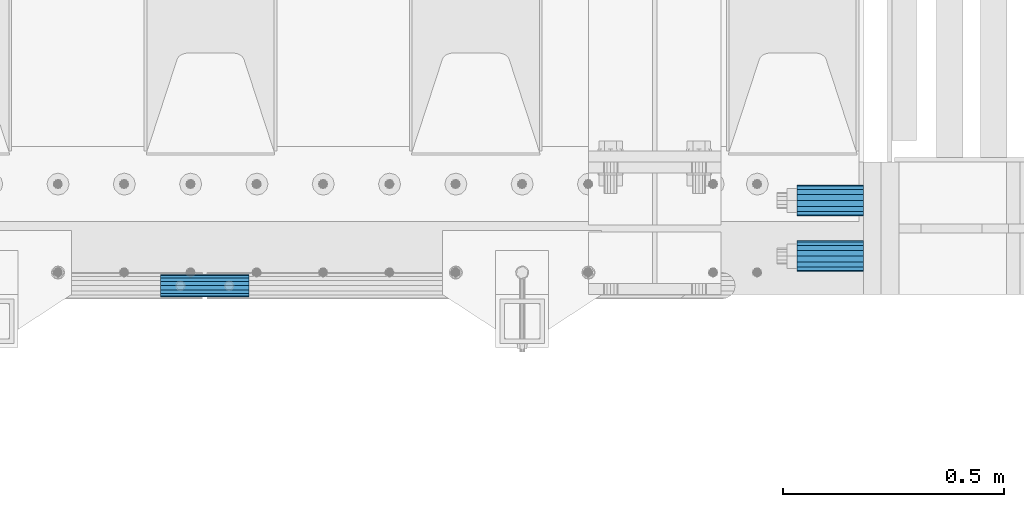
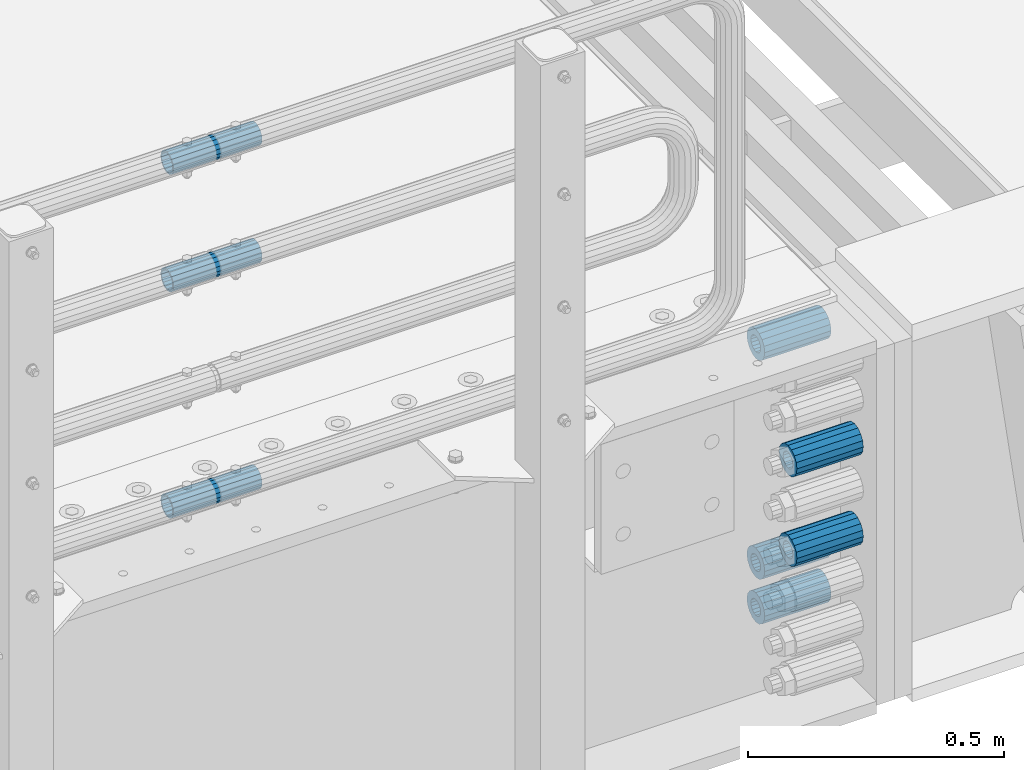
# One storey, part 117 of 193: 8 beams.
"""IFC2X3 building model written with IfcOpenShell, lengths in millimetres."""

from ifc_helpers import new_model, si_unit, frame, origin_with_axes, place, context, subcontext, project, spatial, faceted_brep, material, type_object, element, save


model = new_model("IFC2X3")

# Units and contexts
model_context = context("Model", 3, precision=1e-05, world=origin_with_axes())
body_context = subcontext(model_context, "Body", "Model", "MODEL_VIEW")
ifc_project = project(units=[si_unit("LENGTHUNIT", "METRE", prefix="MILLI"), si_unit("AREAUNIT", "SQUARE_METRE"), si_unit("VOLUMEUNIT", "CUBIC_METRE"), si_unit("MASSUNIT", "GRAM", prefix="KILO"), si_unit("TIMEUNIT", "SECOND"), si_unit("PLANEANGLEUNIT", "RADIAN"), si_unit("SOLIDANGLEUNIT", "STERADIAN"), si_unit("THERMODYNAMICTEMPERATUREUNIT", "DEGREE_CELSIUS"), si_unit("LUMINOUSINTENSITYUNIT", "LUMEN")], contexts=[model_context])

# Site, building, storey
site_placement = place(None, origin_with_axes())
site = spatial("IfcSite", under=ifc_project, at=site_placement, CompositionType="ELEMENT")
building_placement = place(site_placement, origin_with_axes())
building = spatial("IfcBuilding", under=site, at=building_placement, Name="Standard", CompositionType="ELEMENT")
storey_placement = place(building_placement, origin_with_axes())
storey = spatial("IfcBuildingStorey", under=building, at=storey_placement, Name="Undefined", CompositionType="ELEMENT", Elevation=0.0)

# Beams
ifc_material = material()
beam_type_1 = type_object("IfcBeamType", PredefinedType="NOTDEFINED")
beam_1_placement = place(storey_placement, frame((-28573.0, 23937.0, -285.0), z_axis=(0.0, 0.0, 1.0), x_axis=(1.0, 0.0, 0.0)))
element("IfcBeam", 1, at=beam_1_placement, inside=storey, type_object=beam_type_1, material=ifc_material, context=body_context, shape_type="Brep", body=[
    faceted_brep([(-1.31236447487026e-07, -18.9999999995498, -6.26823748461902e-09), (0.0, -17.5537111177146, 7.27098521493673), (150.0, -17.5537111177146, 7.27098521493673), (150.0, -19.0, 0.0), (0.0, -13.4350288425449, 13.4350288425444), (150.0, -13.4350288425449, 13.4350288425444), (0.0, -7.27098521493826, 17.5537111177144), (150.0, -7.27098521493826, 17.5537111177144), (-6.29370333626866e-09, 4.49745130026713e-10, 18.9999999937318), (150.0, 0.0, 19.0), (0.0, 7.27098521493826, 17.5537111177144), (150.0, 7.27098521493826, 17.5537111177144), (0.0, 13.4350288425449, 13.4350288425444), (150.0, 13.4350288425449, 13.4350288425444), (0.0, 17.5537111177146, 7.27098521493673), (150.0, 17.5537111177146, 7.27098521493673), (1.33251887746155e-07, 19.0000000004502, -6.26823748461902e-09), (150.0, 19.0, 0.0), (0.0, 17.5537111177146, -7.27098521493673), (150.0, 17.5537111177146, -7.27098521493673), (0.0, 13.4350288425449, -13.4350288425444), (150.0, 13.4350288425449, -13.4350288425444), (0.0, 7.27098521493826, -17.5537111177144), (150.0, 7.27098521493826, -17.5537111177144), (8.30550561659038e-09, 4.49745130026713e-10, -19.0000000062682), (150.0, 0.0, -19.0), (0.0, -7.27098521493826, -17.5537111177144), (150.0, -7.27098521493826, -17.5537111177144), (0.0, -13.4350288425449, -13.4350288425444), (150.0, -13.4350288425449, -13.4350288425444), (0.0, -17.5537111177146, -7.27098521493673), (150.0, -17.5537111177146, -7.27098521493673), (-3.63797880709171e-12, -35.0, 0.0), (-3.63797880709171e-12, -32.335783637895, -13.3939201327776), (150.0, -32.3357836378964, -13.3939201327782), (150.0, -35.0, 0.0), (0.0, -24.7487373415292, -24.7487373415279), (150.0, -24.7487373415279, -24.7487373415292), (0.0, -13.3939201327781, -32.3357836378927), (150.0, -13.3939201327776, -32.335783637895), (0.0, 0.0, -35.0), (150.0, 0.0, -35.0), (0.0, 13.3939201327782, -32.3357836378927), (150.0, 13.3939201327776, -32.335783637895), (0.0, 24.7487373415292, -24.7487373415279), (150.0, 24.7487373415279, -24.7487373415291), (-3.63797880709171e-12, 32.335783637895, -13.3939201327776), (150.0, 32.3357836378964, -13.3939201327781), (-3.63797880709171e-12, 35.0, 0.0), (150.0, 35.0, 0.0), (-7.27595761418343e-12, 32.335783637895, 13.3939201327776), (150.0, 32.3357836378964, 13.3939201327781), (-7.27595761418343e-12, 24.7487373415292, 24.7487373415279), (150.0, 24.7487373415279, 24.7487373415292), (-7.27595761418343e-12, 13.3939201327781, 32.3357836378927), (150.0, 13.3939201327776, 32.335783637895), (-1.09139364212751e-11, 0.0, 35.0), (150.0, 0.0, 35.0), (-7.27595761418343e-12, -13.3939201327781, 32.3357836378927), (150.0, -13.3939201327776, 32.335783637895), (-7.27595761418343e-12, -24.7487373415292, 24.7487373415279), (150.0, -24.7487373415279, 24.7487373415292), (-7.27595761418343e-12, -32.335783637895, 13.3939201327776), (150.0, -32.3357836378964, 13.3939201327781)], [[[0, 1, 2, 3]], [[1, 4, 5, 2]], [[4, 6, 7, 5]], [[6, 8, 9, 7]], [[8, 10, 11, 9]], [[10, 12, 13, 11]], [[12, 14, 15, 13]], [[14, 16, 17, 15]], [[16, 18, 19, 17]], [[18, 20, 21, 19]], [[20, 22, 23, 21]], [[22, 24, 25, 23]], [[24, 26, 27, 25]], [[26, 28, 29, 27]], [[28, 30, 31, 29]], [[30, 0, 3, 31]], [[32, 33, 34, 35]], [[33, 36, 37, 34]], [[36, 38, 39, 37]], [[38, 40, 41, 39]], [[40, 42, 43, 41]], [[42, 44, 45, 43]], [[44, 46, 47, 45]], [[46, 48, 49, 47]], [[48, 50, 51, 49]], [[50, 52, 53, 51]], [[52, 54, 55, 53]], [[54, 56, 57, 55]], [[56, 58, 59, 57]], [[58, 60, 61, 59]], [[60, 62, 63, 61]], [[62, 32, 35, 63]], [[37, 39, 41, 43, 45, 47, 49, 51, 53, 55, 57, 59, 61, 63, 35, 34], [5, 7, 9, 11, 13, 15, 17, 19, 21, 23, 25, 27, 29, 31, 3, 2]], [[62, 60, 58, 56, 54, 52, 50, 48, 46, 44, 42, 40, 38, 36, 33, 32], [30, 28, 26, 24, 22, 20, 18, 16, 14, 12, 10, 8, 6, 4, 1, 0]]]),
])
beam_2_placement = place(storey_placement, frame((-28573.0, 24063.0, -606.0), z_axis=(0.0, 0.0, 1.0), x_axis=(1.0, 0.0, 0.0)))
element("IfcBeam", 2, at=beam_2_placement, inside=storey, type_object=beam_type_1, material=ifc_material, context=body_context, shape_type="Brep", body=[
    faceted_brep([(-1.31236447487026e-07, -18.9999999995498, -6.26823748461902e-09), (0.0, -17.5537111177146, 7.27098521493673), (150.0, -17.5537111177146, 7.27098521493673), (150.0, -19.0, 0.0), (0.0, -13.4350288425449, 13.4350288425444), (150.0, -13.4350288425449, 13.4350288425444), (0.0, -7.27098521493826, 17.5537111177144), (150.0, -7.27098521493826, 17.5537111177144), (-6.29370333626866e-09, 4.49745130026713e-10, 18.9999999937318), (150.0, 0.0, 19.0), (0.0, 7.27098521493826, 17.5537111177144), (150.0, 7.27098521493826, 17.5537111177144), (0.0, 13.4350288425449, 13.4350288425444), (150.0, 13.4350288425449, 13.4350288425444), (0.0, 17.5537111177146, 7.27098521493673), (150.0, 17.5537111177146, 7.27098521493673), (1.33251887746155e-07, 19.0000000004502, -6.26823748461902e-09), (150.0, 19.0, 0.0), (0.0, 17.5537111177146, -7.27098521493673), (150.0, 17.5537111177146, -7.27098521493673), (0.0, 13.4350288425449, -13.4350288425444), (150.0, 13.4350288425449, -13.4350288425444), (0.0, 7.27098521493826, -17.5537111177144), (150.0, 7.27098521493826, -17.5537111177144), (8.30550561659038e-09, 4.49745130026713e-10, -19.0000000062682), (150.0, 0.0, -19.0), (0.0, -7.27098521493826, -17.5537111177144), (150.0, -7.27098521493826, -17.5537111177144), (0.0, -13.4350288425449, -13.4350288425444), (150.0, -13.4350288425449, -13.4350288425444), (0.0, -17.5537111177146, -7.27098521493673), (150.0, -17.5537111177146, -7.27098521493673), (-3.63797880709171e-12, -35.0, 0.0), (-3.63797880709171e-12, -32.335783637895, -13.3939201327776), (150.0, -32.3357836378964, -13.3939201327782), (150.0, -35.0, 0.0), (0.0, -24.7487373415292, -24.7487373415279), (150.0, -24.7487373415279, -24.7487373415292), (0.0, -13.3939201327781, -32.3357836378927), (150.0, -13.3939201327776, -32.335783637895), (0.0, 0.0, -35.0), (150.0, 0.0, -35.0), (0.0, 13.3939201327782, -32.3357836378927), (150.0, 13.3939201327776, -32.335783637895), (0.0, 24.7487373415292, -24.7487373415279), (150.0, 24.7487373415279, -24.7487373415291), (-3.63797880709171e-12, 32.335783637895, -13.3939201327776), (150.0, 32.3357836378964, -13.3939201327781), (-3.63797880709171e-12, 35.0, 0.0), (150.0, 35.0, 0.0), (-7.27595761418343e-12, 32.335783637895, 13.3939201327776), (150.0, 32.3357836378964, 13.3939201327781), (-7.27595761418343e-12, 24.7487373415292, 24.7487373415279), (150.0, 24.7487373415279, 24.7487373415292), (-7.27595761418343e-12, 13.3939201327781, 32.3357836378927), (150.0, 13.3939201327776, 32.335783637895), (-1.09139364212751e-11, 0.0, 35.0), (150.0, 0.0, 35.0), (-7.27595761418343e-12, -13.3939201327781, 32.3357836378927), (150.0, -13.3939201327776, 32.335783637895), (-7.27595761418343e-12, -24.7487373415292, 24.7487373415279), (150.0, -24.7487373415279, 24.7487373415292), (-7.27595761418343e-12, -32.335783637895, 13.3939201327776), (150.0, -32.3357836378964, 13.3939201327781)], [[[0, 1, 2, 3]], [[1, 4, 5, 2]], [[4, 6, 7, 5]], [[6, 8, 9, 7]], [[8, 10, 11, 9]], [[10, 12, 13, 11]], [[12, 14, 15, 13]], [[14, 16, 17, 15]], [[16, 18, 19, 17]], [[18, 20, 21, 19]], [[20, 22, 23, 21]], [[22, 24, 25, 23]], [[24, 26, 27, 25]], [[26, 28, 29, 27]], [[28, 30, 31, 29]], [[30, 0, 3, 31]], [[32, 33, 34, 35]], [[33, 36, 37, 34]], [[36, 38, 39, 37]], [[38, 40, 41, 39]], [[40, 42, 43, 41]], [[42, 44, 45, 43]], [[44, 46, 47, 45]], [[46, 48, 49, 47]], [[48, 50, 51, 49]], [[50, 52, 53, 51]], [[52, 54, 55, 53]], [[54, 56, 57, 55]], [[56, 58, 59, 57]], [[58, 60, 61, 59]], [[60, 62, 63, 61]], [[62, 32, 35, 63]], [[37, 39, 41, 43, 45, 47, 49, 51, 53, 55, 57, 59, 61, 63, 35, 34], [5, 7, 9, 11, 13, 15, 17, 19, 21, 23, 25, 27, 29, 31, 3, 2]], [[62, 60, 58, 56, 54, 52, 50, 48, 46, 44, 42, 40, 38, 36, 33, 32], [30, 28, 26, 24, 22, 20, 18, 16, 14, 12, 10, 8, 6, 4, 1, 0]]]),
])
beam_3_placement = place(storey_placement, frame((-28573.0, 24063.0, -713.0), z_axis=(0.0, 0.0, 1.0), x_axis=(1.0, 0.0, 0.0)))
element("IfcBeam", 3, at=beam_3_placement, inside=storey, type_object=beam_type_1, material=ifc_material, context=body_context, shape_type="Brep", body=[
    faceted_brep([(-1.31236447487026e-07, -18.9999999995498, -6.26823748461902e-09), (0.0, -17.5537111177146, 7.27098521493673), (150.0, -17.5537111177146, 7.27098521493673), (150.0, -19.0, 0.0), (0.0, -13.4350288425449, 13.4350288425444), (150.0, -13.4350288425449, 13.4350288425444), (0.0, -7.27098521493826, 17.5537111177144), (150.0, -7.27098521493826, 17.5537111177144), (-6.29370333626866e-09, 4.49745130026713e-10, 18.9999999937318), (150.0, 0.0, 19.0), (0.0, 7.27098521493826, 17.5537111177144), (150.0, 7.27098521493826, 17.5537111177144), (0.0, 13.4350288425449, 13.4350288425444), (150.0, 13.4350288425449, 13.4350288425444), (0.0, 17.5537111177146, 7.27098521493673), (150.0, 17.5537111177146, 7.27098521493673), (1.33251887746155e-07, 19.0000000004502, -6.26823748461902e-09), (150.0, 19.0, 0.0), (0.0, 17.5537111177146, -7.27098521493673), (150.0, 17.5537111177146, -7.27098521493673), (0.0, 13.4350288425449, -13.4350288425444), (150.0, 13.4350288425449, -13.4350288425444), (0.0, 7.27098521493826, -17.5537111177144), (150.0, 7.27098521493826, -17.5537111177144), (8.30550561659038e-09, 4.49745130026713e-10, -19.0000000062682), (150.0, 0.0, -19.0), (0.0, -7.27098521493826, -17.5537111177144), (150.0, -7.27098521493826, -17.5537111177144), (0.0, -13.4350288425449, -13.4350288425444), (150.0, -13.4350288425449, -13.4350288425444), (0.0, -17.5537111177146, -7.27098521493673), (150.0, -17.5537111177146, -7.27098521493673), (-3.63797880709171e-12, -35.0, 0.0), (-3.63797880709171e-12, -32.335783637895, -13.3939201327776), (150.0, -32.3357836378964, -13.3939201327782), (150.0, -35.0, 0.0), (0.0, -24.7487373415292, -24.7487373415279), (150.0, -24.7487373415279, -24.7487373415292), (0.0, -13.3939201327781, -32.3357836378927), (150.0, -13.3939201327776, -32.335783637895), (0.0, 0.0, -35.0), (150.0, 0.0, -35.0), (0.0, 13.3939201327782, -32.3357836378927), (150.0, 13.3939201327776, -32.335783637895), (0.0, 24.7487373415292, -24.7487373415279), (150.0, 24.7487373415279, -24.7487373415291), (-3.63797880709171e-12, 32.335783637895, -13.3939201327776), (150.0, 32.3357836378964, -13.3939201327781), (-3.63797880709171e-12, 35.0, 0.0), (150.0, 35.0, 0.0), (-7.27595761418343e-12, 32.335783637895, 13.3939201327776), (150.0, 32.3357836378964, 13.3939201327781), (-7.27595761418343e-12, 24.7487373415292, 24.7487373415279), (150.0, 24.7487373415279, 24.7487373415292), (-7.27595761418343e-12, 13.3939201327781, 32.3357836378927), (150.0, 13.3939201327776, 32.335783637895), (-1.09139364212751e-11, 0.0, 35.0), (150.0, 0.0, 35.0), (-7.27595761418343e-12, -13.3939201327781, 32.3357836378927), (150.0, -13.3939201327776, 32.335783637895), (-7.27595761418343e-12, -24.7487373415292, 24.7487373415279), (150.0, -24.7487373415279, 24.7487373415292), (-7.27595761418343e-12, -32.335783637895, 13.3939201327776), (150.0, -32.3357836378964, 13.3939201327781)], [[[0, 1, 2, 3]], [[1, 4, 5, 2]], [[4, 6, 7, 5]], [[6, 8, 9, 7]], [[8, 10, 11, 9]], [[10, 12, 13, 11]], [[12, 14, 15, 13]], [[14, 16, 17, 15]], [[16, 18, 19, 17]], [[18, 20, 21, 19]], [[20, 22, 23, 21]], [[22, 24, 25, 23]], [[24, 26, 27, 25]], [[26, 28, 29, 27]], [[28, 30, 31, 29]], [[30, 0, 3, 31]], [[32, 33, 34, 35]], [[33, 36, 37, 34]], [[36, 38, 39, 37]], [[38, 40, 41, 39]], [[40, 42, 43, 41]], [[42, 44, 45, 43]], [[44, 46, 47, 45]], [[46, 48, 49, 47]], [[48, 50, 51, 49]], [[50, 52, 53, 51]], [[52, 54, 55, 53]], [[54, 56, 57, 55]], [[56, 58, 59, 57]], [[58, 60, 61, 59]], [[60, 62, 63, 61]], [[62, 32, 35, 63]], [[37, 39, 41, 43, 45, 47, 49, 51, 53, 55, 57, 59, 61, 63, 35, 34], [5, 7, 9, 11, 13, 15, 17, 19, 21, 23, 25, 27, 29, 31, 3, 2]], [[62, 60, 58, 56, 54, 52, 50, 48, 46, 44, 42, 40, 38, 36, 33, 32], [30, 28, 26, 24, 22, 20, 18, 16, 14, 12, 10, 8, 6, 4, 1, 0]]]),
])
beam_4_placement = place(storey_placement, frame((-28573.0, 23937.0, -499.0), z_axis=(0.0, 0.0, 1.0), x_axis=(1.0, 0.0, 0.0)))
element("IfcBeam", 4, at=beam_4_placement, inside=storey, type_object=beam_type_1, material=ifc_material, context=body_context, shape_type="Brep", body=[
    faceted_brep([(-1.31236447487026e-07, -18.9999999995498, -6.26823748461902e-09), (0.0, -17.5537111177146, 7.27098521493673), (150.0, -17.5537111177146, 7.27098521493673), (150.0, -19.0, 0.0), (0.0, -13.4350288425449, 13.4350288425444), (150.0, -13.4350288425449, 13.4350288425444), (0.0, -7.27098521493826, 17.5537111177144), (150.0, -7.27098521493826, 17.5537111177144), (-6.29370333626866e-09, 4.49745130026713e-10, 18.9999999937318), (150.0, 0.0, 19.0), (0.0, 7.27098521493826, 17.5537111177144), (150.0, 7.27098521493826, 17.5537111177144), (0.0, 13.4350288425449, 13.4350288425444), (150.0, 13.4350288425449, 13.4350288425444), (0.0, 17.5537111177146, 7.27098521493673), (150.0, 17.5537111177146, 7.27098521493673), (1.33251887746155e-07, 19.0000000004502, -6.26823748461902e-09), (150.0, 19.0, 0.0), (0.0, 17.5537111177146, -7.27098521493673), (150.0, 17.5537111177146, -7.27098521493673), (0.0, 13.4350288425449, -13.4350288425444), (150.0, 13.4350288425449, -13.4350288425444), (0.0, 7.27098521493826, -17.5537111177144), (150.0, 7.27098521493826, -17.5537111177144), (8.30550561659038e-09, 4.49745130026713e-10, -19.0000000062682), (150.0, 0.0, -19.0), (0.0, -7.27098521493826, -17.5537111177144), (150.0, -7.27098521493826, -17.5537111177144), (0.0, -13.4350288425449, -13.4350288425444), (150.0, -13.4350288425449, -13.4350288425444), (0.0, -17.5537111177146, -7.27098521493673), (150.0, -17.5537111177146, -7.27098521493673), (-3.63797880709171e-12, -35.0, 0.0), (-3.63797880709171e-12, -32.335783637895, -13.3939201327776), (150.0, -32.3357836378964, -13.3939201327782), (150.0, -35.0, 0.0), (0.0, -24.7487373415292, -24.7487373415279), (150.0, -24.7487373415279, -24.7487373415292), (0.0, -13.3939201327781, -32.3357836378927), (150.0, -13.3939201327776, -32.335783637895), (0.0, 0.0, -35.0), (150.0, 0.0, -35.0), (0.0, 13.3939201327782, -32.3357836378927), (150.0, 13.3939201327776, -32.335783637895), (0.0, 24.7487373415292, -24.7487373415279), (150.0, 24.7487373415279, -24.7487373415291), (-3.63797880709171e-12, 32.335783637895, -13.3939201327776), (150.0, 32.3357836378964, -13.3939201327781), (-3.63797880709171e-12, 35.0, 0.0), (150.0, 35.0, 0.0), (-7.27595761418343e-12, 32.335783637895, 13.3939201327776), (150.0, 32.3357836378964, 13.3939201327781), (-7.27595761418343e-12, 24.7487373415292, 24.7487373415279), (150.0, 24.7487373415279, 24.7487373415292), (-7.27595761418343e-12, 13.3939201327781, 32.3357836378927), (150.0, 13.3939201327776, 32.335783637895), (-1.09139364212751e-11, 0.0, 35.0), (150.0, 0.0, 35.0), (-7.27595761418343e-12, -13.3939201327781, 32.3357836378927), (150.0, -13.3939201327776, 32.335783637895), (-7.27595761418343e-12, -24.7487373415292, 24.7487373415279), (150.0, -24.7487373415279, 24.7487373415292), (-7.27595761418343e-12, -32.335783637895, 13.3939201327776), (150.0, -32.3357836378964, 13.3939201327781)], [[[0, 1, 2, 3]], [[1, 4, 5, 2]], [[4, 6, 7, 5]], [[6, 8, 9, 7]], [[8, 10, 11, 9]], [[10, 12, 13, 11]], [[12, 14, 15, 13]], [[14, 16, 17, 15]], [[16, 18, 19, 17]], [[18, 20, 21, 19]], [[20, 22, 23, 21]], [[22, 24, 25, 23]], [[24, 26, 27, 25]], [[26, 28, 29, 27]], [[28, 30, 31, 29]], [[30, 0, 3, 31]], [[32, 33, 34, 35]], [[33, 36, 37, 34]], [[36, 38, 39, 37]], [[38, 40, 41, 39]], [[40, 42, 43, 41]], [[42, 44, 45, 43]], [[44, 46, 47, 45]], [[46, 48, 49, 47]], [[48, 50, 51, 49]], [[50, 52, 53, 51]], [[52, 54, 55, 53]], [[54, 56, 57, 55]], [[56, 58, 59, 57]], [[58, 60, 61, 59]], [[60, 62, 63, 61]], [[62, 32, 35, 63]], [[37, 39, 41, 43, 45, 47, 49, 51, 53, 55, 57, 59, 61, 63, 35, 34], [5, 7, 9, 11, 13, 15, 17, 19, 21, 23, 25, 27, 29, 31, 3, 2]], [[62, 60, 58, 56, 54, 52, 50, 48, 46, 44, 42, 40, 38, 36, 33, 32], [30, 28, 26, 24, 22, 20, 18, 16, 14, 12, 10, 8, 6, 4, 1, 0]]]),
])
beam_5_placement = place(storey_placement, frame((-28573.0, 24063.0, -84.0000000000001), z_axis=(0.0, 0.0, 1.0), x_axis=(1.0, 0.0, 0.0)))
element("IfcBeam", 5, at=beam_5_placement, inside=storey, type_object=beam_type_1, material=ifc_material, context=body_context, shape_type="Brep", body=[
    faceted_brep([(-1.31236447487026e-07, -18.9999999995498, -6.26823748461902e-09), (0.0, -17.5537111177146, 7.27098521493673), (150.0, -17.5537111177146, 7.27098521493673), (150.0, -19.0, 0.0), (0.0, -13.4350288425449, 13.4350288425444), (150.0, -13.4350288425449, 13.4350288425444), (0.0, -7.27098521493826, 17.5537111177144), (150.0, -7.27098521493826, 17.5537111177144), (-6.29370333626866e-09, 4.49745130026713e-10, 18.9999999937318), (150.0, 0.0, 19.0), (0.0, 7.27098521493826, 17.5537111177144), (150.0, 7.27098521493826, 17.5537111177144), (0.0, 13.4350288425449, 13.4350288425444), (150.0, 13.4350288425449, 13.4350288425444), (0.0, 17.5537111177146, 7.27098521493673), (150.0, 17.5537111177146, 7.27098521493673), (1.33251887746155e-07, 19.0000000004502, -6.26823748461902e-09), (150.0, 19.0, 0.0), (0.0, 17.5537111177146, -7.27098521493673), (150.0, 17.5537111177146, -7.27098521493673), (0.0, 13.4350288425449, -13.4350288425444), (150.0, 13.4350288425449, -13.4350288425444), (0.0, 7.27098521493826, -17.5537111177144), (150.0, 7.27098521493826, -17.5537111177144), (8.30550561659038e-09, 4.49745130026713e-10, -19.0000000062682), (150.0, 0.0, -19.0), (0.0, -7.27098521493826, -17.5537111177144), (150.0, -7.27098521493826, -17.5537111177144), (0.0, -13.4350288425449, -13.4350288425444), (150.0, -13.4350288425449, -13.4350288425444), (0.0, -17.5537111177146, -7.27098521493673), (150.0, -17.5537111177146, -7.27098521493673), (-3.63797880709171e-12, -35.0, 0.0), (-3.63797880709171e-12, -32.335783637895, -13.3939201327776), (150.0, -32.3357836378964, -13.3939201327782), (150.0, -35.0, 0.0), (0.0, -24.7487373415292, -24.7487373415279), (150.0, -24.7487373415279, -24.7487373415292), (0.0, -13.3939201327781, -32.3357836378927), (150.0, -13.3939201327776, -32.335783637895), (0.0, 0.0, -35.0), (150.0, 0.0, -35.0), (0.0, 13.3939201327782, -32.3357836378927), (150.0, 13.3939201327776, -32.335783637895), (0.0, 24.7487373415292, -24.7487373415279), (150.0, 24.7487373415279, -24.7487373415291), (-3.63797880709171e-12, 32.335783637895, -13.3939201327776), (150.0, 32.3357836378964, -13.3939201327781), (-3.63797880709171e-12, 35.0, 0.0), (150.0, 35.0, 0.0), (-7.27595761418343e-12, 32.335783637895, 13.3939201327776), (150.0, 32.3357836378964, 13.3939201327781), (-7.27595761418343e-12, 24.7487373415292, 24.7487373415279), (150.0, 24.7487373415279, 24.7487373415292), (-7.27595761418343e-12, 13.3939201327781, 32.3357836378927), (150.0, 13.3939201327776, 32.335783637895), (-1.09139364212751e-11, 0.0, 35.0), (150.0, 0.0, 35.0), (-7.27595761418343e-12, -13.3939201327781, 32.3357836378927), (150.0, -13.3939201327776, 32.335783637895), (-7.27595761418343e-12, -24.7487373415292, 24.7487373415279), (150.0, -24.7487373415279, 24.7487373415292), (-7.27595761418343e-12, -32.335783637895, 13.3939201327776), (150.0, -32.3357836378964, 13.3939201327781)], [[[0, 1, 2, 3]], [[1, 4, 5, 2]], [[4, 6, 7, 5]], [[6, 8, 9, 7]], [[8, 10, 11, 9]], [[10, 12, 13, 11]], [[12, 14, 15, 13]], [[14, 16, 17, 15]], [[16, 18, 19, 17]], [[18, 20, 21, 19]], [[20, 22, 23, 21]], [[22, 24, 25, 23]], [[24, 26, 27, 25]], [[26, 28, 29, 27]], [[28, 30, 31, 29]], [[30, 0, 3, 31]], [[32, 33, 34, 35]], [[33, 36, 37, 34]], [[36, 38, 39, 37]], [[38, 40, 41, 39]], [[40, 42, 43, 41]], [[42, 44, 45, 43]], [[44, 46, 47, 45]], [[46, 48, 49, 47]], [[48, 50, 51, 49]], [[50, 52, 53, 51]], [[52, 54, 55, 53]], [[54, 56, 57, 55]], [[56, 58, 59, 57]], [[58, 60, 61, 59]], [[60, 62, 63, 61]], [[62, 32, 35, 63]], [[37, 39, 41, 43, 45, 47, 49, 51, 53, 55, 57, 59, 61, 63, 35, 34], [5, 7, 9, 11, 13, 15, 17, 19, 21, 23, 25, 27, 29, 31, 3, 2]], [[62, 60, 58, 56, 54, 52, 50, 48, 46, 44, 42, 40, 38, 36, 33, 32], [30, 28, 26, 24, 22, 20, 18, 16, 14, 12, 10, 8, 6, 4, 1, 0]]]),
])
beam_type_2 = type_object("IfcBeamType", PredefinedType="NOTDEFINED")
beam_6_placement = place(storey_placement, frame((-30013.0024970001, 23870.1500000004, 149.849999999747), z_axis=(0.0, 0.0, 1.0), x_axis=(1.0, 0.0, 0.0)))
element("IfcBeam", 6, at=beam_6_placement, inside=storey, type_object=beam_type_2, material=ifc_material, context=body_context, shape_type="Brep", body=[
    faceted_brep([(0.0, -21.9000000000015, 0.0), (0.0, -20.232961761998, 8.38076716879547), (200.0, -20.232961761998, 8.38076716879547), (200.0, -21.9000000000015, 0.0), (0.0, -15.4856385079838, 15.4856385079854), (200.0, -15.4856385079838, 15.4856385079854), (0.0, -8.38076716879368, 20.2329617619972), (200.0, -8.38076716879368, 20.2329617619972), (0.0, 0.0, 21.9), (200.0, 0.0, 21.9), (0.0, 8.38076716879368, 20.2329617619972), (200.0, 8.38076716879368, 20.2329617619972), (0.0, 15.4856385079838, 15.4856385079854), (200.0, 15.4856385079838, 15.4856385079854), (0.0, 20.232961761998, 8.38076716879547), (200.0, 20.232961761998, 8.38076716879547), (0.0, 21.9000000000015, 0.0), (200.0, 21.9000000000015, 0.0), (0.0, 20.232961761998, -8.38076716879547), (200.0, 20.232961761998, -8.38076716879547), (0.0, 15.4856385079838, -15.4856385079854), (200.0, 15.4856385079838, -15.4856385079854), (0.0, 8.38076716879368, -20.2329617619972), (200.0, 8.38076716879368, -20.2329617619972), (0.0, 0.0, -21.9), (200.0, 0.0, -21.9), (0.0, -8.38076716879368, -20.2329617619972), (200.0, -8.38076716879368, -20.2329617619972), (0.0, -15.4856385079838, -15.4856385079854), (200.0, -15.4856385079838, -15.4856385079854), (0.0, -20.232961761998, -8.38076716879547), (200.0, -20.232961761998, -8.38076716879547), (0.0, -25.5, 0.0), (0.0, -23.5589280790373, -9.7584275253098), (200.0, -23.5589280790373, -9.7584275253098), (200.0, -25.5, 0.0), (0.0, -18.0312229202573, -18.031222920257), (200.0, -18.0312229202573, -18.031222920257), (0.0, -9.75842752531025, -23.5589280790378), (200.0, -9.75842752531025, -23.5589280790378), (0.0, 0.0, -25.5), (200.0, 0.0, -25.5), (0.0, 9.75842752531025, -23.5589280790378), (200.0, 9.75842752531025, -23.5589280790378), (0.0, 18.0312229202573, -18.031222920257), (200.0, 18.0312229202573, -18.031222920257), (0.0, 23.5589280790373, -9.7584275253098), (200.0, 23.5589280790373, -9.7584275253098), (0.0, 25.5, 0.0), (200.0, 25.5, 0.0), (0.0, 23.5589280790373, 9.7584275253098), (200.0, 23.5589280790373, 9.7584275253098), (0.0, 18.0312229202573, 18.031222920257), (200.0, 18.0312229202573, 18.031222920257), (0.0, 9.75842752531025, 23.5589280790378), (200.0, 9.75842752531025, 23.5589280790378), (0.0, 0.0, 25.5), (200.0, 0.0, 25.5), (0.0, -9.75842752531025, 23.5589280790378), (200.0, -9.75842752531025, 23.5589280790378), (0.0, -18.0312229202573, 18.031222920257), (200.0, -18.0312229202573, 18.031222920257), (0.0, -23.5589280790373, 9.7584275253098), (200.0, -23.5589280790373, 9.7584275253098)], [[[0, 1, 2, 3]], [[1, 4, 5, 2]], [[4, 6, 7, 5]], [[6, 8, 9, 7]], [[8, 10, 11, 9]], [[10, 12, 13, 11]], [[12, 14, 15, 13]], [[14, 16, 17, 15]], [[16, 18, 19, 17]], [[18, 20, 21, 19]], [[20, 22, 23, 21]], [[22, 24, 25, 23]], [[24, 26, 27, 25]], [[26, 28, 29, 27]], [[28, 30, 31, 29]], [[30, 0, 3, 31]], [[32, 33, 34, 35]], [[33, 36, 37, 34]], [[36, 38, 39, 37]], [[38, 40, 41, 39]], [[40, 42, 43, 41]], [[42, 44, 45, 43]], [[44, 46, 47, 45]], [[46, 48, 49, 47]], [[48, 50, 51, 49]], [[50, 52, 53, 51]], [[52, 54, 55, 53]], [[54, 56, 57, 55]], [[56, 58, 59, 57]], [[58, 60, 61, 59]], [[60, 62, 63, 61]], [[62, 32, 35, 63]], [[37, 39, 41, 43, 45, 47, 49, 51, 53, 55, 57, 59, 61, 63, 35, 34], [5, 7, 9, 11, 13, 15, 17, 19, 21, 23, 25, 27, 29, 31, 3, 2]], [[62, 60, 58, 56, 54, 52, 50, 48, 46, 44, 42, 40, 38, 36, 33, 32], [30, 28, 26, 24, 22, 20, 18, 16, 14, 12, 10, 8, 6, 4, 1, 0]]]),
])
beam_7_placement = place(storey_placement, frame((-30013.0024970001, 23870.1500000004, 689.849999999747), z_axis=(0.0, 0.0, 1.0), x_axis=(1.0, 0.0, 0.0)))
element("IfcBeam", 7, at=beam_7_placement, inside=storey, type_object=beam_type_2, material=ifc_material, context=body_context, shape_type="Brep", body=[
    faceted_brep([(0.0, -21.9000000000015, 0.0), (0.0, -20.232961761998, 8.38076716879547), (200.0, -20.232961761998, 8.38076716879547), (200.0, -21.9000000000015, 0.0), (0.0, -15.4856385079838, 15.4856385079854), (200.0, -15.4856385079838, 15.4856385079854), (0.0, -8.38076716879368, 20.2329617619972), (200.0, -8.38076716879368, 20.2329617619972), (0.0, 0.0, 21.9), (200.0, 0.0, 21.9), (0.0, 8.38076716879368, 20.2329617619972), (200.0, 8.38076716879368, 20.2329617619972), (0.0, 15.4856385079838, 15.4856385079854), (200.0, 15.4856385079838, 15.4856385079854), (0.0, 20.232961761998, 8.38076716879547), (200.0, 20.232961761998, 8.38076716879547), (0.0, 21.9000000000015, 0.0), (200.0, 21.9000000000015, 0.0), (0.0, 20.232961761998, -8.38076716879547), (200.0, 20.232961761998, -8.38076716879547), (0.0, 15.4856385079838, -15.4856385079854), (200.0, 15.4856385079838, -15.4856385079854), (0.0, 8.38076716879368, -20.2329617619972), (200.0, 8.38076716879368, -20.2329617619972), (0.0, 0.0, -21.9), (200.0, 0.0, -21.9), (0.0, -8.38076716879368, -20.2329617619972), (200.0, -8.38076716879368, -20.2329617619972), (0.0, -15.4856385079838, -15.4856385079854), (200.0, -15.4856385079838, -15.4856385079854), (0.0, -20.232961761998, -8.38076716879547), (200.0, -20.232961761998, -8.38076716879547), (0.0, -25.5, 0.0), (0.0, -23.5589280790373, -9.7584275253098), (200.0, -23.5589280790373, -9.7584275253098), (200.0, -25.5, 0.0), (0.0, -18.0312229202573, -18.031222920257), (200.0, -18.0312229202573, -18.031222920257), (0.0, -9.75842752531025, -23.5589280790378), (200.0, -9.75842752531025, -23.5589280790378), (0.0, 0.0, -25.5), (200.0, 0.0, -25.5), (0.0, 9.75842752531025, -23.5589280790378), (200.0, 9.75842752531025, -23.5589280790378), (0.0, 18.0312229202573, -18.031222920257), (200.0, 18.0312229202573, -18.031222920257), (0.0, 23.5589280790373, -9.7584275253098), (200.0, 23.5589280790373, -9.7584275253098), (0.0, 25.5, 0.0), (200.0, 25.5, 0.0), (0.0, 23.5589280790373, 9.7584275253098), (200.0, 23.5589280790373, 9.7584275253098), (0.0, 18.0312229202573, 18.031222920257), (200.0, 18.0312229202573, 18.031222920257), (0.0, 9.75842752531025, 23.5589280790378), (200.0, 9.75842752531025, 23.5589280790378), (0.0, 0.0, 25.5), (200.0, 0.0, 25.5), (0.0, -9.75842752531025, 23.5589280790378), (200.0, -9.75842752531025, 23.5589280790378), (0.0, -18.0312229202573, 18.031222920257), (200.0, -18.0312229202573, 18.031222920257), (0.0, -23.5589280790373, 9.7584275253098), (200.0, -23.5589280790373, 9.7584275253098)], [[[0, 1, 2, 3]], [[1, 4, 5, 2]], [[4, 6, 7, 5]], [[6, 8, 9, 7]], [[8, 10, 11, 9]], [[10, 12, 13, 11]], [[12, 14, 15, 13]], [[14, 16, 17, 15]], [[16, 18, 19, 17]], [[18, 20, 21, 19]], [[20, 22, 23, 21]], [[22, 24, 25, 23]], [[24, 26, 27, 25]], [[26, 28, 29, 27]], [[28, 30, 31, 29]], [[30, 0, 3, 31]], [[32, 33, 34, 35]], [[33, 36, 37, 34]], [[36, 38, 39, 37]], [[38, 40, 41, 39]], [[40, 42, 43, 41]], [[42, 44, 45, 43]], [[44, 46, 47, 45]], [[46, 48, 49, 47]], [[48, 50, 51, 49]], [[50, 52, 53, 51]], [[52, 54, 55, 53]], [[54, 56, 57, 55]], [[56, 58, 59, 57]], [[58, 60, 61, 59]], [[60, 62, 63, 61]], [[62, 32, 35, 63]], [[37, 39, 41, 43, 45, 47, 49, 51, 53, 55, 57, 59, 61, 63, 35, 34], [5, 7, 9, 11, 13, 15, 17, 19, 21, 23, 25, 27, 29, 31, 3, 2]], [[62, 60, 58, 56, 54, 52, 50, 48, 46, 44, 42, 40, 38, 36, 33, 32], [30, 28, 26, 24, 22, 20, 18, 16, 14, 12, 10, 8, 6, 4, 1, 0]]]),
])
beam_8_placement = place(storey_placement, frame((-30013.0024970001, 23870.1500000005, 969.849999999747), z_axis=(0.0, 0.0, 1.0), x_axis=(1.0, 0.0, 0.0)))
element("IfcBeam", 8, at=beam_8_placement, inside=storey, type_object=beam_type_2, material=ifc_material, context=body_context, shape_type="Brep", body=[
    faceted_brep([(0.0, -21.9000000000015, 0.0), (0.0, -20.232961761998, 8.38076716879547), (200.0, -20.232961761998, 8.38076716879547), (200.0, -21.9000000000015, 0.0), (0.0, -15.4856385079838, 15.4856385079854), (200.0, -15.4856385079838, 15.4856385079854), (0.0, -8.38076716879368, 20.2329617619972), (200.0, -8.38076716879368, 20.2329617619972), (0.0, 0.0, 21.9), (200.0, 0.0, 21.9), (0.0, 8.38076716879368, 20.2329617619972), (200.0, 8.38076716879368, 20.2329617619972), (0.0, 15.4856385079838, 15.4856385079854), (200.0, 15.4856385079838, 15.4856385079854), (0.0, 20.232961761998, 8.38076716879547), (200.0, 20.232961761998, 8.38076716879547), (0.0, 21.9000000000015, 0.0), (200.0, 21.9000000000015, 0.0), (0.0, 20.232961761998, -8.38076716879547), (200.0, 20.232961761998, -8.38076716879547), (0.0, 15.4856385079838, -15.4856385079854), (200.0, 15.4856385079838, -15.4856385079854), (0.0, 8.38076716879368, -20.2329617619972), (200.0, 8.38076716879368, -20.2329617619972), (0.0, 0.0, -21.9), (200.0, 0.0, -21.9), (0.0, -8.38076716879368, -20.2329617619972), (200.0, -8.38076716879368, -20.2329617619972), (0.0, -15.4856385079838, -15.4856385079854), (200.0, -15.4856385079838, -15.4856385079854), (0.0, -20.232961761998, -8.38076716879547), (200.0, -20.232961761998, -8.38076716879547), (0.0, -25.5, 0.0), (0.0, -23.5589280790373, -9.7584275253098), (200.0, -23.5589280790373, -9.7584275253098), (200.0, -25.5, 0.0), (0.0, -18.0312229202573, -18.031222920257), (200.0, -18.0312229202573, -18.031222920257), (0.0, -9.75842752531025, -23.5589280790378), (200.0, -9.75842752531025, -23.5589280790378), (0.0, 0.0, -25.5), (200.0, 0.0, -25.5), (0.0, 9.75842752531025, -23.5589280790378), (200.0, 9.75842752531025, -23.5589280790378), (0.0, 18.0312229202573, -18.031222920257), (200.0, 18.0312229202573, -18.031222920257), (0.0, 23.5589280790373, -9.7584275253098), (200.0, 23.5589280790373, -9.7584275253098), (0.0, 25.5, 0.0), (200.0, 25.5, 0.0), (0.0, 23.5589280790373, 9.7584275253098), (200.0, 23.5589280790373, 9.7584275253098), (0.0, 18.0312229202573, 18.031222920257), (200.0, 18.0312229202573, 18.031222920257), (0.0, 9.75842752531025, 23.5589280790378), (200.0, 9.75842752531025, 23.5589280790378), (0.0, 0.0, 25.5), (200.0, 0.0, 25.5), (0.0, -9.75842752531025, 23.5589280790378), (200.0, -9.75842752531025, 23.5589280790378), (0.0, -18.0312229202573, 18.031222920257), (200.0, -18.0312229202573, 18.031222920257), (0.0, -23.5589280790373, 9.7584275253098), (200.0, -23.5589280790373, 9.7584275253098)], [[[0, 1, 2, 3]], [[1, 4, 5, 2]], [[4, 6, 7, 5]], [[6, 8, 9, 7]], [[8, 10, 11, 9]], [[10, 12, 13, 11]], [[12, 14, 15, 13]], [[14, 16, 17, 15]], [[16, 18, 19, 17]], [[18, 20, 21, 19]], [[20, 22, 23, 21]], [[22, 24, 25, 23]], [[24, 26, 27, 25]], [[26, 28, 29, 27]], [[28, 30, 31, 29]], [[30, 0, 3, 31]], [[32, 33, 34, 35]], [[33, 36, 37, 34]], [[36, 38, 39, 37]], [[38, 40, 41, 39]], [[40, 42, 43, 41]], [[42, 44, 45, 43]], [[44, 46, 47, 45]], [[46, 48, 49, 47]], [[48, 50, 51, 49]], [[50, 52, 53, 51]], [[52, 54, 55, 53]], [[54, 56, 57, 55]], [[56, 58, 59, 57]], [[58, 60, 61, 59]], [[60, 62, 63, 61]], [[62, 32, 35, 63]], [[37, 39, 41, 43, 45, 47, 49, 51, 53, 55, 57, 59, 61, 63, 35, 34], [5, 7, 9, 11, 13, 15, 17, 19, 21, 23, 25, 27, 29, 31, 3, 2]], [[62, 60, 58, 56, 54, 52, 50, 48, 46, 44, 42, 40, 38, 36, 33, 32], [30, 28, 26, 24, 22, 20, 18, 16, 14, 12, 10, 8, 6, 4, 1, 0]]]),
])

save(model, "model.ifc")
